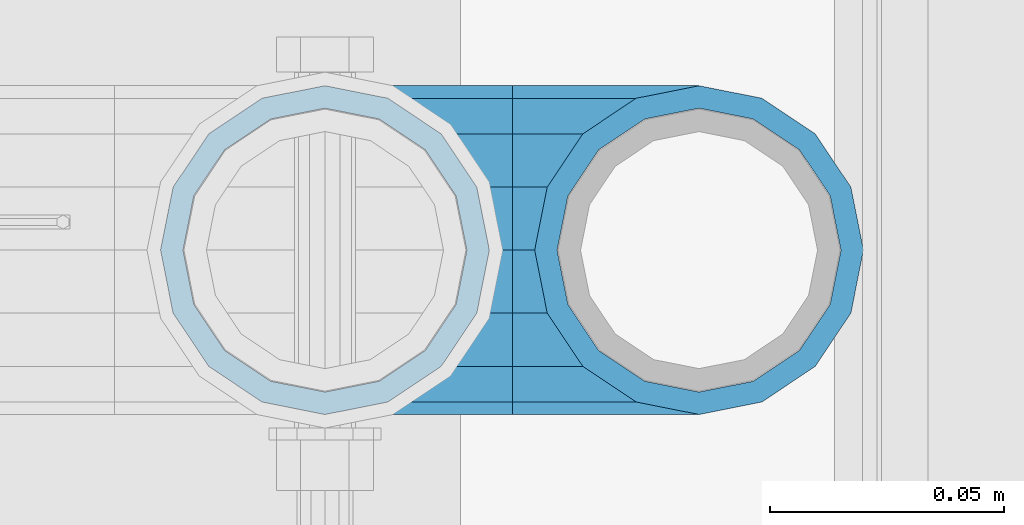
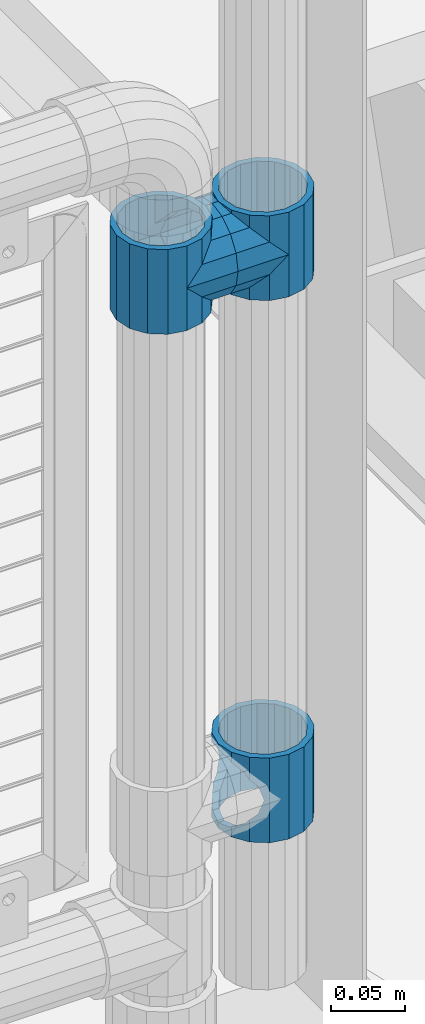
# One storey, part 150 of 219: 5 beams.
"""IFC2X3 building model written with IfcOpenShell, lengths in millimetres."""

from ifc_helpers import new_model, si_unit, frame, origin_with_axes, place, context, subcontext, project, spatial, faceted_brep, material, type_object, element, save


model = new_model("IFC2X3")

# Units and contexts
model_context = context("Model", 3, precision=1e-05, world=origin_with_axes())
body_context = subcontext(model_context, "Body", "Model", "MODEL_VIEW")
ifc_project = project(units=[si_unit("LENGTHUNIT", "METRE", prefix="MILLI"), si_unit("AREAUNIT", "SQUARE_METRE"), si_unit("VOLUMEUNIT", "CUBIC_METRE"), si_unit("MASSUNIT", "GRAM", prefix="KILO"), si_unit("TIMEUNIT", "SECOND"), si_unit("PLANEANGLEUNIT", "RADIAN"), si_unit("SOLIDANGLEUNIT", "STERADIAN"), si_unit("THERMODYNAMICTEMPERATUREUNIT", "DEGREE_CELSIUS"), si_unit("LUMINOUSINTENSITYUNIT", "LUMEN")], contexts=[model_context])

# Site, building, storey
site_placement = place(None, origin_with_axes())
site = spatial("IfcSite", under=ifc_project, at=site_placement, CompositionType="ELEMENT")
building_placement = place(site_placement, origin_with_axes())
building = spatial("IfcBuilding", under=site, at=building_placement, Name="Standard", CompositionType="ELEMENT")
storey_placement = place(building_placement, origin_with_axes())
storey = spatial("IfcBuildingStorey", under=building, at=storey_placement, Name="Undefined", CompositionType="ELEMENT", Elevation=0.0)

# Beams
ifc_material = material(Name="Misc_Undefined")
beam_type = type_object("IfcBeamType", PredefinedType="NOTDEFINED")
beam_1_placement = place(storey_placement, frame((13511.0, 31664.5, 433.820000000004), z_axis=(1.0, 0.0, 0.0), x_axis=(0.0, 0.0, -1.0)))
element("IfcBeam", 1, at=beam_1_placement, inside=storey, type_object=beam_type, material=ifc_material, context=body_context, shape_type="Brep", body=[
    faceted_brep([(46.7644421722801, 28.0397438117179, -11.6144421722802), (46.7644421722801, 28.0397438117179, -20.0882031229849), (51.5310424080006, 24.8548033587067, -24.8548033587067), (56.6106908090114, 21.46069080901, -27.1226768591096), (56.6106908090114, 21.46069080901, -21.4606908090118), (61.9623795176703, 13.4513226476338, -32.4743655677721), (63.1897438117172, 11.614442172282, -32.8397438117172), (63.1897438117172, 11.614442172282, -28.0397438117179), (65.4999999999997, 0.0, -35.1499999999996), (65.4999999999997, 0.0, -30.3500000000004), (63.1897438117172, -11.614442172282, -32.839743811719), (63.1897438117172, -11.614442172282, -28.0397438117179), (61.9623795176747, -13.4513226476338, -32.4743655677721), (56.6106908090114, -21.46069080901, -27.1226768591077), (56.6106908090114, -21.46069080901, -21.4606908090118), (51.5310424080006, -24.8548033587067, -24.8548033587067), (46.7644421722801, -28.0397438117179, -20.0882031229739), (46.7644421722801, -28.0397438117179, -11.6144421722802), (35.1499999999996, -30.3499999999985, -16.6306603983649), (35.1499999999996, -30.35, 0.0), (23.5355578277191, -28.0397438117179, -20.0882031229739), (23.5355578277191, -28.0397438117179, -11.6144421722802), (18.7689575919921, -24.8548033587067, -24.8548033587067), (13.6893091909879, -21.46069080901, -27.1226768591077), (13.6893091909879, -21.46069080901, -21.4606908090118), (8.33762048232455, -13.4513226476338, -32.4743655677721), (7.11025618828211, -11.614442172282, -32.839743811719), (7.11025618828211, -11.614442172282, -28.0397438117179), (4.79999999999961, 0.0, -35.1499999999996), (4.79999999999961, 0.0, -30.3500000000004), (7.11025618828211, 11.614442172282, -32.8397438117172), (7.11025618828211, 11.614442172282, -28.0397438117179), (8.33762048232455, 13.4513226476338, -32.4743655677721), (13.6893091909879, 21.46069080901, -27.1226768591096), (13.6893091909879, 21.46069080901, -21.4606908090118), (18.7689575919987, 24.8548033587067, -24.8548033587067), (23.5355578277192, 28.0397438117179, -20.0882031229849), (23.5355578277192, 28.0397438117179, -11.6144421722802), (35.1499999999996, 30.3499999999985, -16.6306603983739), (35.1499999999996, 30.35, 0.0), (0.0, 32.4743655677703, -13.4513226476338), (0.0, 35.1500000000015, 0.0), (70.2999999999993, 35.1500000000015, 0.0), (70.2999999999993, 32.4743655677703, -13.4513226476338), (0.0, 32.4743655677703, 13.4513226476338), (70.2999999999993, 32.4743655677703, 13.4513226476338), (0.0, 24.8548033587067, 24.8548033587067), (70.2999999999993, 24.8548033587067, 24.8548033587067), (0.0, 13.4513226476338, 32.4743655677721), (70.2999999999993, 13.4513226476338, 32.4743655677721), (0.0, 0.0, 35.1500000000015), (70.2999999999993, 0.0, 35.1499999999996), (0.0, -13.4513226476338, 32.4743655677721), (70.2999999999993, -13.4513226476338, 32.4743655677721), (0.0, -24.8548033587067, 24.8548033587067), (70.2999999999993, -24.8548033587067, 24.8548033587067), (0.0, -32.4743655677703, 13.4513226476338), (70.2999999999993, -32.4743655677703, 13.4513226476338), (0.0, -35.1500000000015, 0.0), (70.2999999999993, -35.1500000000015, 0.0), (70.2999999999993, -30.3499999999985, 0.0), (70.2999999999993, -28.0397438117179, -11.6144421722802), (70.2999999999993, -21.46069080901, -21.4606908090118), (70.2999999999993, -11.614442172282, -28.0397438117179), (70.2999999999993, 0.0, -30.3500000000004), (70.2999999999993, 11.614442172282, -28.0397438117179), (70.2999999999993, 21.46069080901, -21.4606908090118), (70.2999999999993, 28.0397438117179, -11.6144421722802), (0.0, -28.0397438117179, -11.6144421722802), (0.0, -30.3499999999985, 0.0), (0.0, -21.46069080901, -21.4606908090118), (0.0, -11.614442172282, -28.0397438117179), (0.0, 0.0, -30.3500000000004), (0.0, 11.614442172282, -28.0397438117179), (0.0, 21.46069080901, -21.4606908090118), (0.0, 28.0397438117179, -11.6144421722802), (0.0, 30.3499999999985, 0.0), (70.2999999999993, 30.3499999999985, 0.0), (0.0, 28.0397438117179, 11.6144421722802), (70.2999999999993, 28.0397438117179, 11.6144421722802), (0.0, 21.46069080901, 21.4606908090118), (70.2999999999993, 21.46069080901, 21.4606908090118), (0.0, 11.614442172282, 28.0397438117179), (70.2999999999993, 11.614442172282, 28.0397438117179), (0.0, 0.0, 30.3500000000004), (70.2999999999993, 0.0, 30.3500000000004), (0.0, -11.614442172282, 28.0397438117179), (70.2999999999993, -11.614442172282, 28.0397438117179), (0.0, -21.46069080901, 21.4606908090118), (70.2999999999993, -21.46069080901, 21.4606908090118), (0.0, -28.0397438117179, 11.6144421722802), (70.2999999999993, -28.0397438117179, 11.6144421722802), (70.2999999999993, -24.8548033587067, -24.8548033587067), (70.2999999999993, -13.4513226476338, -32.4743655677721), (70.2999999999993, 0.0, -35.1499999999996), (70.2999999999993, 13.4513226476338, -32.4743655677721), (70.2999999999993, 24.8548033587067, -24.8548033587067), (70.2999999999993, -32.4743655677703, -13.4513226476338), (0.0, -32.4743655677703, -13.4513226476338), (0.0, 24.8548033587067, -24.8548033587067), (0.0, 13.4513226476338, -32.4743655677721), (0.0, 0.0, -35.1500000000015), (0.0, -13.4513226476338, -32.4743655677721), (0.0, -24.8548033587067, -24.8548033587067)], [[[0, 1, 2, 3, 4]], [[4, 3, 5, 6, 7]], [[7, 6, 8, 9]], [[9, 8, 10, 11]], [[11, 10, 12, 13, 14]], [[14, 13, 15, 16, 17]], [[17, 16, 18, 19]], [[19, 18, 20, 21]], [[21, 20, 22, 23, 24]], [[24, 23, 25, 26, 27]], [[27, 26, 28, 29]], [[29, 28, 30, 31]], [[31, 30, 32, 33, 34]], [[34, 33, 35, 36, 37]], [[37, 36, 38, 39]], [[39, 38, 1, 0]], [[40, 41, 42, 43]], [[41, 44, 45, 42]], [[44, 46, 47, 45]], [[46, 48, 49, 47]], [[48, 50, 51, 49]], [[50, 52, 53, 51]], [[52, 54, 55, 53]], [[54, 56, 57, 55]], [[56, 58, 59, 57]], [[60, 61, 17, 19]], [[61, 62, 14, 17]], [[62, 63, 11, 14]], [[63, 64, 9, 11]], [[64, 65, 7, 9]], [[65, 66, 4, 7]], [[66, 67, 0, 4]], [[68, 69, 19, 21]], [[70, 68, 21, 24]], [[71, 70, 24, 27]], [[72, 71, 27, 29]], [[73, 72, 29, 31]], [[74, 73, 31, 34]], [[75, 74, 34, 37]], [[76, 75, 37, 39]], [[67, 77, 39, 0]], [[78, 76, 39, 77, 79]], [[80, 78, 79, 81]], [[82, 80, 81, 83]], [[84, 82, 83, 85]], [[86, 84, 85, 87]], [[88, 86, 87, 89]], [[90, 88, 89, 91]], [[19, 69, 90, 91, 60]], [[92, 93, 94, 95, 96, 43, 42, 45, 47, 49, 51, 53, 55, 57, 59, 97], [89, 87, 85, 83, 81, 79, 77, 67, 66, 65, 64, 63, 62, 61, 60, 91]], [[58, 98, 97, 59]], [[56, 54, 52, 50, 48, 46, 44, 41, 40, 99, 100, 101, 102, 103, 98, 58], [68, 70, 71, 72, 73, 74, 75, 76, 78, 80, 82, 84, 86, 88, 90, 69]], [[32, 100, 99, 35, 33]], [[28, 101, 100, 32, 30]], [[102, 101, 28, 26, 25]], [[103, 102, 25, 23, 22]], [[15, 92, 97, 98, 103, 22, 20, 18, 16]], [[12, 93, 92, 15, 13]], [[8, 94, 93, 12, 10]], [[95, 94, 8, 6, 5]], [[96, 95, 5, 3, 2]], [[35, 99, 40, 43, 96, 2, 1, 38, 36]]]),
])
beam_2_placement = place(storey_placement, frame((13431.0, 31664.5, 848.670000000003), z_axis=(0.0, -1.0, 0.0), x_axis=(1.0, 0.0, 0.0)))
element("IfcBeam", 2, at=beam_2_placement, inside=storey, type_object=beam_type, material=ifc_material, context=body_context, shape_type="Brep", body=[
    faceted_brep([(0.0, 0.0, -35.1500000000015), (13.4513226476338, -13.4513226476329, -32.4743655677703), (13.4513226476338, 13.4513226476329, -32.4743655677703), (32.4743655677721, 32.4743655677717, 13.4513226476338), (32.4743655677721, 26.8123795176755, 13.4513226476338), (27.1226768591096, 21.4606908090117, 21.46069080901), (24.8548033587067, 16.3810424080078, 24.8548033587067), (24.8548033587067, 24.8548033587072, 24.8548033587067), (0.0, 0.0, 35.1500000000015), (13.4513226476338, 13.4513226476329, 32.4743655677703), (13.4513226476338, -13.4513226476329, 32.4743655677703), (20.0882031229849, 11.6144421722805, 28.0397438117179), (16.6306603983739, 0.0, 30.3499999999985), (20.0882031229849, -11.6144421722805, 28.0397438117179), (24.8548033587067, -16.3810424080013, 24.8548033587067), (24.8548033587067, -24.8548033587072, 24.8548033587067), (27.1226768591096, -21.4606908090117, 21.46069080901), (32.4743655677721, -26.8123795176755, 13.4513226476338), (32.4743655677721, -32.4743655677717, 13.4513226476338), (32.8397438117172, -28.0397438117175, 11.614442172282), (35.1499999999996, -30.35, 0.0), (35.1499999999996, -35.15, 0.0), (32.4743655677721, -26.8123795176712, -13.4513226476338), (32.4743655677721, -32.4743655677717, -13.4513226476338), (32.8397438117172, -28.0397438117175, -11.614442172282), (24.8548033587067, -16.3810424080013, -24.8548033587067), (24.8548033587067, -24.8548033587072, -24.8548033587067), (27.1226768591077, -21.4606908090117, -21.46069080901), (20.0882031229739, -11.6144421722805, -28.0397438117179), (16.6306603983649, 0.0, -30.3499999999985), (20.0882031229739, 11.6144421722805, -28.0397438117179), (24.8548033587067, 16.3810424080013, -24.8548033587067), (24.8548033587067, 24.8548033587072, -24.8548033587067), (27.1226768591077, 21.4606908090117, -21.46069080901), (32.4743655677721, 26.8123795176755, -13.4513226476338), (32.4743655677721, 32.4743655677717, -13.4513226476338), (32.8397438117172, 28.0397438117175, -11.614442172282), (35.1499999999996, 30.35, 0.0), (35.1499999999996, 35.15, 0.0), (32.8397438117172, 28.0397438117175, 11.614442172282), (40.1500000000015, -35.15, 0.0), (40.1500000000015, -32.4743655677717, 13.4513226476338), (40.1500000000015, -24.8548033587072, 24.8548033587067), (40.1500000000015, -13.4513226476329, 32.4743655677703), (40.1500000000015, 0.0, 35.1500000000015), (40.1500000000015, 13.4513226476329, 32.4743655677703), (40.1500000000015, 24.8548033587072, 24.8548033587067), (40.1500000000015, 32.4743655677717, 13.4513226476338), (40.1500000000015, 35.15, 0.0), (40.1500000000015, -24.8548033587072, -24.8548033587067), (40.1500000000015, -32.4743655677717, -13.4513226476338), (40.1500000000015, -13.4513226476329, -32.4743655677703), (40.1500000000015, 0.0, -35.1500000000015), (40.1500000000015, 13.4513226476329, -32.4743655677703), (40.1500000000015, 24.8548033587072, -24.8548033587067), (40.1500000000015, 32.4743655677717, -13.4513226476338), (40.1500000000015, -21.4606908090117, 21.46069080901), (40.1500000000015, -11.6144421722805, 28.0397438117179), (40.1500000000015, 0.0, 30.3499999999985), (40.1500000000015, 11.6144421722805, 28.0397438117179), (40.1500000000015, 21.4606908090117, 21.46069080901), (40.1500000000015, 28.0397438117175, 11.614442172282), (40.1500000000015, 30.35, 0.0), (40.1500000000015, 28.0397438117175, -11.614442172282), (40.1500000000015, 21.4606908090117, -21.46069080901), (40.1500000000015, 11.6144421722805, -28.0397438117179), (40.1500000000015, 0.0, -30.3499999999985), (40.1500000000015, -11.6144421722805, -28.0397438117179), (40.1500000000015, -21.4606908090117, -21.46069080901), (40.1500000000015, -28.0397438117175, -11.614442172282), (40.1500000000015, -30.35, 0.0), (40.1500000000015, -28.0397438117175, 11.614442172282)], [[[0, 1, 2]], [[3, 4, 5, 6, 7]], [[8, 9, 10]], [[7, 6, 11, 12, 13, 14, 15, 10, 9]], [[16, 17, 18, 15, 14]], [[19, 20, 21, 18, 17]], [[22, 23, 21, 20, 24]], [[25, 26, 23, 22, 27]], [[2, 1, 26, 25, 28, 29, 30, 31, 32]], [[32, 31, 33, 34, 35]], [[35, 34, 36, 37, 38]], [[38, 37, 39, 4, 3]], [[40, 41, 18, 21]], [[41, 42, 15, 18]], [[42, 43, 10, 15]], [[43, 44, 8, 10]], [[44, 45, 9, 8]], [[45, 46, 7, 9]], [[46, 47, 3, 7]], [[47, 48, 38, 3]], [[49, 50, 23, 26]], [[51, 49, 26, 1]], [[52, 51, 1, 0]], [[53, 52, 0, 2]], [[54, 53, 2, 32]], [[55, 54, 32, 35]], [[48, 55, 35, 38]], [[50, 40, 21, 23]], [[49, 51, 52, 53, 54, 55, 48, 47, 46, 45, 44, 43, 42, 41, 40, 50], [56, 57, 58, 59, 60, 61, 62, 63, 64, 65, 66, 67, 68, 69, 70, 71]], [[63, 62, 37, 36]], [[33, 64, 63, 36, 34]], [[30, 65, 64, 33, 31]], [[66, 65, 30, 29]], [[67, 66, 29, 28]], [[68, 67, 28, 25, 27]], [[69, 68, 27, 22, 24]], [[70, 69, 24, 20]], [[71, 70, 20, 19]], [[16, 56, 71, 19, 17]], [[13, 57, 56, 16, 14]], [[58, 57, 13, 12]], [[59, 58, 12, 11]], [[60, 59, 11, 6, 5]], [[61, 60, 5, 4, 39]], [[62, 61, 39, 37]]]),
])
beam_3_placement = place(storey_placement, frame((13511.0, 31664.5, 848.670000000003), z_axis=(0.0, 1.0, 0.0), x_axis=(-1.0, 0.0, 0.0)))
element("IfcBeam", 3, at=beam_3_placement, inside=storey, type_object=beam_type, material=ifc_material, context=body_context, shape_type="Brep", body=[
    faceted_brep([(0.0, 0.0, -35.1500000000015), (13.4513226476338, -13.4513226476329, -32.4743655677703), (13.4513226476338, 13.4513226476329, -32.4743655677703), (27.1226768591096, -21.4606908090117, 21.46069080901), (32.4743655677721, -26.8123795176755, 13.4513226476338), (32.4743655677721, -32.4743655677717, 13.4513226476338), (24.8548033587067, -24.8548033587072, 24.8548033587067), (24.8548033587067, -16.3810424080013, 24.8548033587067), (32.8397438117172, -28.0397438117175, 11.614442172282), (35.1499999999996, -30.35, 0.0), (35.1499999999996, -35.15, 0.0), (32.4743655677721, -26.8123795176712, -13.4513226476338), (32.4743655677721, -32.4743655677717, -13.4513226476338), (32.8397438117172, -28.0397438117175, -11.614442172282), (24.8548033587067, -16.3810424080013, -24.8548033587067), (24.8548033587067, -24.8548033587072, -24.8548033587067), (27.1226768591077, -21.4606908090117, -21.46069080901), (20.0882031229739, -11.6144421722805, -28.0397438117179), (16.6306603983649, 0.0, -30.3499999999985), (20.0882031229739, 11.6144421722805, -28.0397438117179), (24.8548033587067, 16.3810424080013, -24.8548033587067), (24.8548033587067, 24.8548033587072, -24.8548033587067), (27.1226768591077, 21.4606908090117, -21.46069080901), (32.4743655677721, 26.8123795176755, -13.4513226476338), (32.4743655677721, 32.4743655677717, -13.4513226476338), (32.8397438117172, 28.0397438117175, -11.614442172282), (35.1499999999996, 30.35, 0.0), (35.1499999999996, 35.15, 0.0), (32.8397438117172, 28.0397438117175, 11.614442172282), (32.4743655677721, 26.8123795176755, 13.4513226476338), (32.4743655677721, 32.4743655677717, 13.4513226476338), (27.1226768591096, 21.4606908090117, 21.46069080901), (24.8548033587067, 16.3810424080078, 24.8548033587067), (24.8548033587067, 24.8548033587072, 24.8548033587067), (0.0, 0.0, 35.1500000000015), (13.4513226476338, 13.4513226476329, 32.4743655677703), (13.4513226476338, -13.4513226476329, 32.4743655677703), (20.0882031229849, 11.6144421722805, 28.0397438117179), (16.6306603983739, 0.0, 30.3499999999985), (20.0882031229849, -11.6144421722805, 28.0397438117179), (40.1500000000015, -35.15, 0.0), (40.1500000000015, -32.4743655677717, 13.4513226476338), (40.1500000000015, -24.8548033587072, 24.8548033587067), (40.1500000000015, -13.4513226476329, 32.4743655677703), (40.1500000000015, 0.0, 35.1500000000015), (40.1500000000015, -24.8548033587072, -24.8548033587067), (40.1500000000015, -32.4743655677717, -13.4513226476338), (40.1500000000015, -13.4513226476329, -32.4743655677703), (40.1500000000015, 0.0, -35.1500000000015), (40.1500000000015, 13.4513226476329, -32.4743655677703), (40.1500000000015, 24.8548033587072, -24.8548033587067), (40.1500000000015, 32.4743655677717, -13.4513226476338), (40.1500000000015, 35.15, 0.0), (40.1500000000015, 32.4743655677717, 13.4513226476338), (40.1500000000015, 24.8548033587072, 24.8548033587067), (40.1500000000015, 13.4513226476329, 32.4743655677703), (40.1500000000015, -21.4606908090117, 21.46069080901), (40.1500000000015, -11.6144421722805, 28.0397438117179), (40.1500000000015, 0.0, 30.3499999999985), (40.1500000000015, 11.6144421722805, 28.0397438117179), (40.1500000000015, 21.4606908090117, 21.46069080901), (40.1500000000015, 28.0397438117175, 11.614442172282), (40.1500000000015, 30.35, 0.0), (40.1500000000015, 28.0397438117175, -11.614442172282), (40.1500000000015, 21.4606908090117, -21.46069080901), (40.1500000000015, 11.6144421722805, -28.0397438117179), (40.1500000000015, 0.0, -30.3499999999985), (40.1500000000015, -11.6144421722805, -28.0397438117179), (40.1500000000015, -21.4606908090117, -21.46069080901), (40.1500000000015, -28.0397438117175, -11.614442172282), (40.1500000000015, -30.35, 0.0), (40.1500000000015, -28.0397438117175, 11.614442172282)], [[[0, 1, 2]], [[3, 4, 5, 6, 7]], [[8, 9, 10, 5, 4]], [[11, 12, 10, 9, 13]], [[14, 15, 12, 11, 16]], [[2, 1, 15, 14, 17, 18, 19, 20, 21]], [[21, 20, 22, 23, 24]], [[24, 23, 25, 26, 27]], [[27, 26, 28, 29, 30]], [[30, 29, 31, 32, 33]], [[34, 35, 36]], [[33, 32, 37, 38, 39, 7, 6, 36, 35]], [[40, 41, 5, 10]], [[41, 42, 6, 5]], [[42, 43, 36, 6]], [[43, 44, 34, 36]], [[45, 46, 12, 15]], [[47, 45, 15, 1]], [[48, 47, 1, 0]], [[49, 48, 0, 2]], [[50, 49, 2, 21]], [[51, 50, 21, 24]], [[52, 51, 24, 27]], [[53, 52, 27, 30]], [[54, 53, 30, 33]], [[55, 54, 33, 35]], [[44, 55, 35, 34]], [[46, 40, 10, 12]], [[45, 47, 48, 49, 50, 51, 52, 53, 54, 55, 44, 43, 42, 41, 40, 46], [56, 57, 58, 59, 60, 61, 62, 63, 64, 65, 66, 67, 68, 69, 70, 71]], [[59, 58, 38, 37]], [[60, 59, 37, 32, 31]], [[61, 60, 31, 29, 28]], [[62, 61, 28, 26]], [[63, 62, 26, 25]], [[22, 64, 63, 25, 23]], [[19, 65, 64, 22, 20]], [[66, 65, 19, 18]], [[67, 66, 18, 17]], [[68, 67, 17, 14, 16]], [[69, 68, 16, 11, 13]], [[70, 69, 13, 9]], [[71, 70, 9, 8]], [[3, 56, 71, 8, 4]], [[39, 57, 56, 3, 7]], [[58, 57, 39, 38]]]),
])
beam_4_placement = place(storey_placement, frame((13431.0, 31664.5, 883.820000000003), z_axis=(-1.0, 0.0, 0.0), x_axis=(0.0, 0.0, -1.0)))
element("IfcBeam", 4, at=beam_4_placement, inside=storey, type_object=beam_type, material=ifc_material, context=body_context, shape_type="Brep", body=[
    faceted_brep([(13.6893091909879, -21.46069080901, -21.4606908090118), (13.6893091909879, -21.46069080901, -27.1226768591077), (8.33762048232455, -13.4513226476338, -32.4743655677721), (7.11025618828211, -11.614442172282, -32.839743811719), (7.11025618828211, -11.614442172282, -28.0397438117179), (23.5355578277191, -28.0397438117179, -11.6144421722802), (23.5355578277191, -28.0397438117179, -20.0882031229739), (18.7689575919921, -24.8548033587067, -24.8548033587067), (35.1499999999996, -30.35, 0.0), (35.1499999999996, -30.3499999999985, -16.6306603983649), (46.7644421722801, -28.0397438117179, -11.6144421722802), (46.7644421722801, -28.0397438117179, -20.0882031229739), (56.6106908090114, -21.46069080901, -21.4606908090118), (56.6106908090114, -21.46069080901, -27.1226768591077), (51.5310424080006, -24.8548033587067, -24.8548033587067), (63.1897438117172, -11.614442172282, -28.0397438117179), (63.1897438117172, -11.614442172282, -32.839743811719), (61.9623795176747, -13.4513226476338, -32.4743655677721), (65.4999999999997, 0.0, -30.3500000000004), (65.4999999999997, 0.0, -35.1499999999996), (63.1897438117172, 11.614442172282, -28.0397438117179), (63.1897438117172, 11.614442172282, -32.8397438117172), (56.6106908090114, 21.46069080901, -21.4606908090118), (56.6106908090114, 21.46069080901, -27.1226768591096), (61.9623795176703, 13.4513226476338, -32.4743655677721), (46.7644421722801, 28.0397438117179, -11.6144421722802), (46.7644421722801, 28.0397438117179, -20.0882031229849), (51.5310424080006, 24.8548033587067, -24.8548033587067), (35.1499999999996, 30.35, 0.0), (35.1499999999996, 30.3499999999985, -16.6306603983739), (23.5355578277192, 28.0397438117179, -11.6144421722802), (23.5355578277192, 28.0397438117179, -20.0882031229849), (13.6893091909879, 21.46069080901, -21.4606908090118), (13.6893091909879, 21.46069080901, -27.1226768591096), (18.7689575919987, 24.8548033587067, -24.8548033587067), (7.11025618828211, 11.614442172282, -28.0397438117179), (7.11025618828211, 11.614442172282, -32.8397438117172), (8.33762048232455, 13.4513226476338, -32.4743655677721), (4.79999999999961, 0.0, -30.3500000000004), (4.79999999999961, 0.0, -35.1499999999996), (0.0, 21.46069080901, 21.4606908090118), (0.0, 28.0397438117179, 11.6144421722802), (70.2999999999993, 28.0397438117179, 11.6144421722802), (70.2999999999993, 21.46069080901, 21.4606908090118), (0.0, 11.614442172282, 28.0397438117179), (70.2999999999993, 11.614442172282, 28.0397438117179), (0.0, 0.0, 30.3500000000004), (70.2999999999993, 0.0, 30.3500000000004), (0.0, -11.614442172282, 28.0397438117179), (70.2999999999993, -11.614442172282, 28.0397438117179), (0.0, -21.46069080901, 21.4606908090118), (70.2999999999993, -21.46069080901, 21.4606908090118), (0.0, -28.0397438117179, 11.6144421722802), (70.2999999999993, -28.0397438117179, 11.6144421722802), (0.0, -24.8548033587067, -24.8548033587067), (0.0, -13.4513226476338, -32.4743655677721), (0.0, 0.0, -35.1500000000015), (0.0, -32.4743655677703, 13.4513226476338), (0.0, -35.1500000000015, 0.0), (70.2999999999993, -35.1500000000015, 0.0), (70.2999999999993, -32.4743655677703, 13.4513226476338), (0.0, -24.8548033587067, 24.8548033587067), (70.2999999999993, -24.8548033587067, 24.8548033587067), (0.0, -13.4513226476338, 32.4743655677721), (70.2999999999993, -13.4513226476338, 32.4743655677721), (0.0, 0.0, 35.1500000000015), (70.2999999999993, 0.0, 35.1499999999996), (0.0, 13.4513226476338, 32.4743655677721), (70.2999999999993, 13.4513226476338, 32.4743655677721), (0.0, 24.8548033587067, 24.8548033587067), (70.2999999999993, 24.8548033587067, 24.8548033587067), (0.0, 32.4743655677703, 13.4513226476338), (70.2999999999993, 32.4743655677703, 13.4513226476338), (0.0, 35.1500000000015, 0.0), (70.2999999999993, 35.1500000000015, 0.0), (0.0, 32.4743655677703, -13.4513226476338), (70.2999999999993, 32.4743655677703, -13.4513226476338), (70.2999999999993, -13.4513226476338, -32.4743655677721), (70.2999999999993, -24.8548033587067, -24.8548033587067), (70.2999999999993, 0.0, -35.1499999999996), (70.2999999999993, 13.4513226476338, -32.4743655677721), (70.2999999999993, 24.8548033587067, -24.8548033587067), (0.0, 24.8548033587067, -24.8548033587067), (0.0, 13.4513226476338, -32.4743655677721), (70.2999999999993, -32.4743655677703, -13.4513226476338), (0.0, -32.4743655677703, -13.4513226476338), (0.0, -28.0397438117179, -11.6144421722802), (0.0, -21.46069080901, -21.4606908090118), (0.0, -11.614442172282, -28.0397438117179), (0.0, 0.0, -30.3500000000004), (0.0, 11.614442172282, -28.0397438117179), (0.0, 21.46069080901, -21.4606908090118), (0.0, 28.0397438117179, -11.6144421722802), (0.0, 30.3499999999985, 0.0), (0.0, -30.3499999999985, 0.0), (70.2999999999993, 30.3499999999985, 0.0), (70.2999999999993, 28.0397438117179, -11.6144421722802), (70.2999999999993, 21.46069080901, -21.4606908090118), (70.2999999999993, 11.614442172282, -28.0397438117179), (70.2999999999993, 0.0, -30.3500000000004), (70.2999999999993, -11.614442172282, -28.0397438117179), (70.2999999999993, -21.46069080901, -21.4606908090118), (70.2999999999993, -28.0397438117179, -11.6144421722802), (70.2999999999993, -30.3499999999985, 0.0)], [[[0, 1, 2, 3, 4]], [[5, 6, 7, 1, 0]], [[8, 9, 6, 5]], [[10, 11, 9, 8]], [[12, 13, 14, 11, 10]], [[15, 16, 17, 13, 12]], [[18, 19, 16, 15]], [[20, 21, 19, 18]], [[22, 23, 24, 21, 20]], [[25, 26, 27, 23, 22]], [[28, 29, 26, 25]], [[30, 31, 29, 28]], [[32, 33, 34, 31, 30]], [[35, 36, 37, 33, 32]], [[38, 39, 36, 35]], [[4, 3, 39, 38]], [[40, 41, 42, 43]], [[44, 40, 43, 45]], [[46, 44, 45, 47]], [[48, 46, 47, 49]], [[50, 48, 49, 51]], [[52, 50, 51, 53]], [[54, 55, 2, 1, 7]], [[55, 56, 39, 3, 2]], [[57, 58, 59, 60]], [[61, 57, 60, 62]], [[63, 61, 62, 64]], [[65, 63, 64, 66]], [[67, 65, 66, 68]], [[69, 67, 68, 70]], [[71, 69, 70, 72]], [[73, 71, 72, 74]], [[75, 73, 74, 76]], [[17, 77, 78, 14, 13]], [[19, 79, 77, 17, 16]], [[80, 79, 19, 21, 24]], [[81, 80, 24, 23, 27]], [[34, 82, 75, 76, 81, 27, 26, 29, 31]], [[37, 83, 82, 34, 33]], [[39, 56, 83, 37, 36]], [[14, 78, 84, 85, 54, 7, 6, 9, 11]], [[58, 85, 84, 59]], [[57, 61, 63, 65, 67, 69, 71, 73, 75, 82, 83, 56, 55, 54, 85, 58], [86, 87, 88, 89, 90, 91, 92, 93, 41, 40, 44, 46, 48, 50, 52, 94]], [[90, 89, 38, 35]], [[91, 90, 35, 32]], [[92, 91, 32, 30]], [[93, 92, 30, 28]], [[41, 93, 28, 95, 42]], [[96, 95, 28, 25]], [[97, 96, 25, 22]], [[98, 97, 22, 20]], [[99, 98, 20, 18]], [[100, 99, 18, 15]], [[101, 100, 15, 12]], [[102, 101, 12, 10]], [[103, 102, 10, 8]], [[78, 77, 79, 80, 81, 76, 74, 72, 70, 68, 66, 64, 62, 60, 59, 84], [51, 49, 47, 45, 43, 42, 95, 96, 97, 98, 99, 100, 101, 102, 103, 53]], [[8, 94, 52, 53, 103]], [[86, 94, 8, 5]], [[87, 86, 5, 0]], [[88, 87, 0, 4]], [[89, 88, 4, 38]]]),
])
beam_5_placement = place(storey_placement, frame((13511.0, 31664.5, 883.820000000003), z_axis=(1.0, 0.0, 0.0), x_axis=(0.0, 0.0, -1.0)))
element("IfcBeam", 5, at=beam_5_placement, inside=storey, type_object=beam_type, material=ifc_material, context=body_context, shape_type="Brep", body=[
    faceted_brep([(46.7644421722801, 28.0397438117179, -11.6144421722802), (46.7644421722801, 28.0397438117179, -20.0882031229849), (51.5310424080006, 24.8548033587067, -24.8548033587067), (56.6106908090114, 21.46069080901, -27.1226768591096), (56.6106908090114, 21.46069080901, -21.4606908090118), (61.9623795176703, 13.4513226476338, -32.4743655677721), (63.1897438117172, 11.614442172282, -32.8397438117172), (63.1897438117172, 11.614442172282, -28.0397438117179), (65.4999999999997, 0.0, -35.1499999999996), (65.4999999999997, 0.0, -30.3500000000004), (63.1897438117172, -11.614442172282, -32.839743811719), (63.1897438117172, -11.614442172282, -28.0397438117179), (61.9623795176747, -13.4513226476338, -32.4743655677721), (56.6106908090114, -21.46069080901, -27.1226768591077), (56.6106908090114, -21.46069080901, -21.4606908090118), (51.5310424080006, -24.8548033587067, -24.8548033587067), (46.7644421722801, -28.0397438117179, -20.0882031229739), (46.7644421722801, -28.0397438117179, -11.6144421722802), (35.1499999999996, -30.3499999999985, -16.6306603983649), (35.1499999999996, -30.35, 0.0), (23.5355578277191, -28.0397438117179, -20.0882031229739), (23.5355578277191, -28.0397438117179, -11.6144421722802), (18.7689575919921, -24.8548033587067, -24.8548033587067), (13.6893091909879, -21.46069080901, -27.1226768591077), (13.6893091909879, -21.46069080901, -21.4606908090118), (8.33762048232455, -13.4513226476338, -32.4743655677721), (7.11025618828211, -11.614442172282, -32.839743811719), (7.11025618828211, -11.614442172282, -28.0397438117179), (4.79999999999961, 0.0, -35.1499999999996), (4.79999999999961, 0.0, -30.3500000000004), (7.11025618828211, 11.614442172282, -32.8397438117172), (7.11025618828211, 11.614442172282, -28.0397438117179), (8.33762048232455, 13.4513226476338, -32.4743655677721), (13.6893091909879, 21.46069080901, -27.1226768591096), (13.6893091909879, 21.46069080901, -21.4606908090118), (18.7689575919987, 24.8548033587067, -24.8548033587067), (23.5355578277192, 28.0397438117179, -20.0882031229849), (23.5355578277192, 28.0397438117179, -11.6144421722802), (35.1499999999996, 30.3499999999985, -16.6306603983739), (35.1499999999996, 30.35, 0.0), (0.0, 32.4743655677703, -13.4513226476338), (0.0, 35.1500000000015, 0.0), (70.2999999999993, 35.1500000000015, 0.0), (70.2999999999993, 32.4743655677703, -13.4513226476338), (0.0, 32.4743655677703, 13.4513226476338), (70.2999999999993, 32.4743655677703, 13.4513226476338), (0.0, 24.8548033587067, 24.8548033587067), (70.2999999999993, 24.8548033587067, 24.8548033587067), (0.0, 13.4513226476338, 32.4743655677721), (70.2999999999993, 13.4513226476338, 32.4743655677721), (0.0, 0.0, 35.1500000000015), (70.2999999999993, 0.0, 35.1499999999996), (0.0, -13.4513226476338, 32.4743655677721), (70.2999999999993, -13.4513226476338, 32.4743655677721), (0.0, -24.8548033587067, 24.8548033587067), (70.2999999999993, -24.8548033587067, 24.8548033587067), (0.0, -32.4743655677703, 13.4513226476338), (70.2999999999993, -32.4743655677703, 13.4513226476338), (0.0, -35.1500000000015, 0.0), (70.2999999999993, -35.1500000000015, 0.0), (70.2999999999993, -30.3499999999985, 0.0), (70.2999999999993, -28.0397438117179, -11.6144421722802), (70.2999999999993, -21.46069080901, -21.4606908090118), (70.2999999999993, -11.614442172282, -28.0397438117179), (70.2999999999993, 0.0, -30.3500000000004), (70.2999999999993, 11.614442172282, -28.0397438117179), (70.2999999999993, 21.46069080901, -21.4606908090118), (70.2999999999993, 28.0397438117179, -11.6144421722802), (0.0, -28.0397438117179, -11.6144421722802), (0.0, -30.3499999999985, 0.0), (0.0, -21.46069080901, -21.4606908090118), (0.0, -11.614442172282, -28.0397438117179), (0.0, 0.0, -30.3500000000004), (0.0, 11.614442172282, -28.0397438117179), (0.0, 21.46069080901, -21.4606908090118), (0.0, 28.0397438117179, -11.6144421722802), (0.0, 30.3499999999985, 0.0), (70.2999999999993, 30.3499999999985, 0.0), (0.0, 28.0397438117179, 11.6144421722802), (70.2999999999993, 28.0397438117179, 11.6144421722802), (0.0, 21.46069080901, 21.4606908090118), (70.2999999999993, 21.46069080901, 21.4606908090118), (0.0, 11.614442172282, 28.0397438117179), (70.2999999999993, 11.614442172282, 28.0397438117179), (0.0, 0.0, 30.3500000000004), (70.2999999999993, 0.0, 30.3500000000004), (0.0, -11.614442172282, 28.0397438117179), (70.2999999999993, -11.614442172282, 28.0397438117179), (0.0, -21.46069080901, 21.4606908090118), (70.2999999999993, -21.46069080901, 21.4606908090118), (0.0, -28.0397438117179, 11.6144421722802), (70.2999999999993, -28.0397438117179, 11.6144421722802), (70.2999999999993, -24.8548033587067, -24.8548033587067), (70.2999999999993, -13.4513226476338, -32.4743655677721), (70.2999999999993, 0.0, -35.1499999999996), (70.2999999999993, 13.4513226476338, -32.4743655677721), (70.2999999999993, 24.8548033587067, -24.8548033587067), (70.2999999999993, -32.4743655677703, -13.4513226476338), (0.0, -32.4743655677703, -13.4513226476338), (0.0, 24.8548033587067, -24.8548033587067), (0.0, 13.4513226476338, -32.4743655677721), (0.0, 0.0, -35.1500000000015), (0.0, -13.4513226476338, -32.4743655677721), (0.0, -24.8548033587067, -24.8548033587067)], [[[0, 1, 2, 3, 4]], [[4, 3, 5, 6, 7]], [[7, 6, 8, 9]], [[9, 8, 10, 11]], [[11, 10, 12, 13, 14]], [[14, 13, 15, 16, 17]], [[17, 16, 18, 19]], [[19, 18, 20, 21]], [[21, 20, 22, 23, 24]], [[24, 23, 25, 26, 27]], [[27, 26, 28, 29]], [[29, 28, 30, 31]], [[31, 30, 32, 33, 34]], [[34, 33, 35, 36, 37]], [[37, 36, 38, 39]], [[39, 38, 1, 0]], [[40, 41, 42, 43]], [[41, 44, 45, 42]], [[44, 46, 47, 45]], [[46, 48, 49, 47]], [[48, 50, 51, 49]], [[50, 52, 53, 51]], [[52, 54, 55, 53]], [[54, 56, 57, 55]], [[56, 58, 59, 57]], [[60, 61, 17, 19]], [[61, 62, 14, 17]], [[62, 63, 11, 14]], [[63, 64, 9, 11]], [[64, 65, 7, 9]], [[65, 66, 4, 7]], [[66, 67, 0, 4]], [[68, 69, 19, 21]], [[70, 68, 21, 24]], [[71, 70, 24, 27]], [[72, 71, 27, 29]], [[73, 72, 29, 31]], [[74, 73, 31, 34]], [[75, 74, 34, 37]], [[76, 75, 37, 39]], [[67, 77, 39, 0]], [[78, 76, 39, 77, 79]], [[80, 78, 79, 81]], [[82, 80, 81, 83]], [[84, 82, 83, 85]], [[86, 84, 85, 87]], [[88, 86, 87, 89]], [[90, 88, 89, 91]], [[19, 69, 90, 91, 60]], [[92, 93, 94, 95, 96, 43, 42, 45, 47, 49, 51, 53, 55, 57, 59, 97], [89, 87, 85, 83, 81, 79, 77, 67, 66, 65, 64, 63, 62, 61, 60, 91]], [[58, 98, 97, 59]], [[56, 54, 52, 50, 48, 46, 44, 41, 40, 99, 100, 101, 102, 103, 98, 58], [68, 70, 71, 72, 73, 74, 75, 76, 78, 80, 82, 84, 86, 88, 90, 69]], [[32, 100, 99, 35, 33]], [[28, 101, 100, 32, 30]], [[102, 101, 28, 26, 25]], [[103, 102, 25, 23, 22]], [[15, 92, 97, 98, 103, 22, 20, 18, 16]], [[12, 93, 92, 15, 13]], [[8, 94, 93, 12, 10]], [[95, 94, 8, 6, 5]], [[96, 95, 5, 3, 2]], [[35, 99, 40, 43, 96, 2, 1, 38, 36]]]),
])

save(model, "model.ifc")
